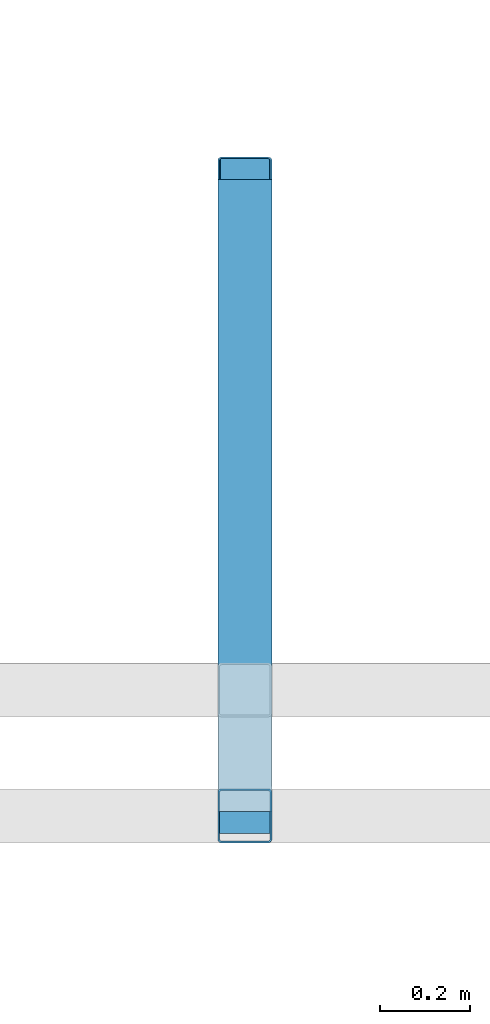
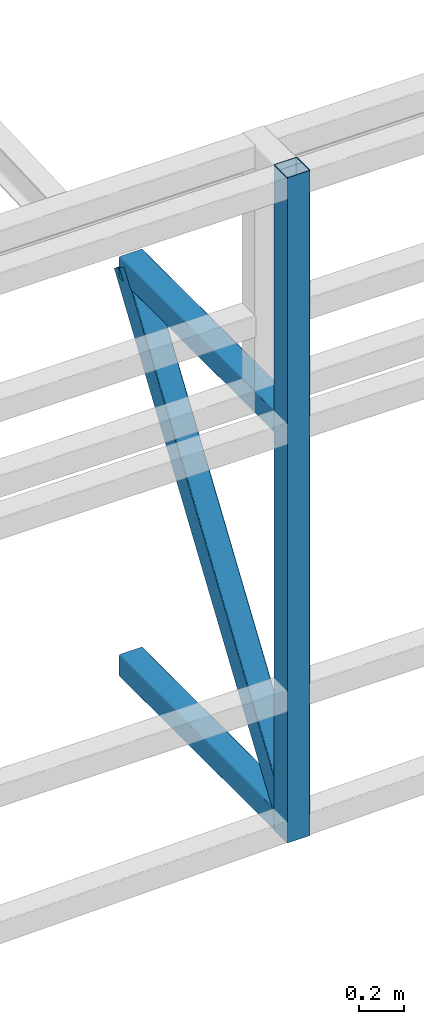
# One storey, part 115 of 215: 3 beams, 1 member, 4 elements without a shape of their own.
"""IFC2X3 building model written with IfcOpenShell, lengths in millimetres."""

from ifc_helpers import new_model, si_unit, frame, origin_with_axes, origin_2d_with_axis, place, context, subcontext, project, spatial, hollow_rectangle, extrude, material, type_object, element, aggregate, save


model = new_model("IFC2X3")

# Units and contexts
model_context = context("Model", 3, precision=1e-05, world=origin_with_axes())
body_context = subcontext(model_context, "Body", "Model", "MODEL_VIEW")
ifc_project = project(units=[si_unit("LENGTHUNIT", "METRE", prefix="MILLI"), si_unit("AREAUNIT", "SQUARE_METRE"), si_unit("VOLUMEUNIT", "CUBIC_METRE"), si_unit("MASSUNIT", "GRAM", prefix="KILO"), si_unit("TIMEUNIT", "SECOND"), si_unit("PLANEANGLEUNIT", "RADIAN"), si_unit("SOLIDANGLEUNIT", "STERADIAN"), si_unit("THERMODYNAMICTEMPERATUREUNIT", "DEGREE_CELSIUS"), si_unit("LUMINOUSINTENSITYUNIT", "LUMEN")], contexts=[model_context])

# Site, building, storey
site_placement = place(None, origin_with_axes())
site = spatial("IfcSite", under=ifc_project, at=site_placement, CompositionType="ELEMENT")
building_placement = place(site_placement, origin_with_axes())
building = spatial("IfcBuilding", under=site, at=building_placement, Name="Undefined", CompositionType="ELEMENT")
storey_placement = place(building_placement, origin_with_axes())
storey = spatial("IfcBuildingStorey", under=building, at=storey_placement, Name="Undefined", CompositionType="ELEMENT", Elevation=0.0)

# Assembly, beam
assembly_1_placement = place(storey_placement, origin_with_axes())
assembly_1 = element("IfcElementAssembly", 1, at=assembly_1_placement, inside=storey, Name="Steel Assembly", AssemblyPlace="NOTDEFINED", PredefinedType="RIGID_FRAME")
ifc_material = material(Name="STEEL/S275JR")
beam_type = type_object("IfcBeamType", PredefinedType="NOTDEFINED")
beam_1_placement = place(assembly_1_placement, frame((134605.010285256, 34554.9274900555, 827.155539383219), z_axis=(0.0, 0.0, 1.0), x_axis=(-6.93889390390723e-18, -1.0, -3.46944695195361e-18)))
beam_1 = element("IfcBeam", 2, at=beam_1_placement, type_object=beam_type, material=ifc_material, Name="LISSE", context=body_context, shape_type="SweptSolid", body=[
    extrude(hollow_rectangle(XDim=120.0, YDim=120.0, WallThickness=4.0, InnerFilletRadius=4.0, OuterFilletRadius=8.0, at=origin_2d_with_axis()), frame((1404.9181154153, 1.48751491493898e-19, -2.84217094304217e-14), z_axis=(-1.0, 0.0, 0.0), x_axis=(-6.93889390390723e-18, -1.0, -3.46944695195361e-18)), (0.0, 0.0, 1.0), 1404.9),
])
aggregate(assembly_1, [beam_1])

assembly_2_placement = place(storey_placement, origin_with_axes())
assembly_2 = element("IfcElementAssembly", 3, at=assembly_2_placement, inside=storey, Name="Steel Assembly", AssemblyPlace="NOTDEFINED", PredefinedType="RIGID_FRAME")
beam_2_placement = place(assembly_2_placement, frame((134605.011693152, 34554.9240843928, 2963.99602185051), z_axis=(0.0, 0.0, -1.0), x_axis=(-4.41999996209638e-07, -0.999999999999642, 7.22000000069896e-07)))
beam_2 = element("IfcBeam", 4, at=beam_2_placement, type_object=beam_type, material=ifc_material, Name="LISSE", context=body_context, shape_type="SweptSolid", body=[
    extrude(hollow_rectangle(XDim=120.0, YDim=120.0, WallThickness=4.0, InnerFilletRadius=4.0, OuterFilletRadius=8.0, at=origin_2d_with_axis()), frame((1404.89231313232, 5.39143026605448e-20, -1.48748759570922e-19), z_axis=(-1.0, 0.0, 0.0), x_axis=(-6.93889390390723e-18, -1.0, -3.46944695195361e-18)), (0.0, 0.0, 1.0), 1404.9),
])
aggregate(assembly_2, [beam_2])

assembly_3_placement = place(storey_placement, origin_with_axes())
assembly_3 = element("IfcElementAssembly", 5, at=assembly_3_placement, inside=storey, Name="Steel Assembly", AssemblyPlace="NOTDEFINED", PredefinedType="RIGID_FRAME")
beam_3_placement = place(assembly_3_placement, frame((134605.011410734, 33139.9549939152, 4339.19097174734), z_axis=(1.91399999311775e-06, -0.999999999998168, 0.0), x_axis=(0.0, 0.0, -1.0)))
beam_3 = element("IfcBeam", 6, at=beam_3_placement, type_object=beam_type, material=ifc_material, Name="LISSE", context=body_context, shape_type="SweptSolid", body=[
    extrude(hollow_rectangle(XDim=120.0, YDim=120.0, WallThickness=4.0, InnerFilletRadius=4.0, OuterFilletRadius=8.0, at=origin_2d_with_axis()), frame((3570.69100096889, 0.0, 0.0), z_axis=(-1.0, 0.0, 0.0), x_axis=(-6.93889390390723e-18, -1.0, -3.46944695195361e-18)), (0.0, 0.0, 1.0), 3570.7),
])
aggregate(assembly_3, [beam_3])

# Assembly, member
assembly_4_placement = place(storey_placement, origin_with_axes())
assembly_4 = element("IfcElementAssembly", 7, at=assembly_4_placement, inside=storey, Name="Steel Assembly", AssemblyPlace="NOTDEFINED", PredefinedType="RIGID_FRAME")
member_type = type_object("IfcMemberType", PredefinedType="NOTDEFINED")
member_placement = place(assembly_4_placement, frame((134605.014869548, 33150.0095363629, 887.155531883219), z_axis=(-0.00165792200077796, -0.828283564382141, 0.560306691258506), x_axis=(-1.26800000093105e-06, 0.560307463278539, 0.828284701411756)))
member = element("IfcMember", 8, at=member_placement, type_object=member_type, material=ifc_material, Name="LISSE", context=body_context, shape_type="SweptSolid", body=[
    extrude(hollow_rectangle(XDim=120.0, YDim=120.0, WallThickness=4.0, InnerFilletRadius=4.0, OuterFilletRadius=8.0, at=origin_2d_with_axis()), frame((2507.39931134504, 0.0, 0.0), z_axis=(-1.0, 0.0, 0.0), x_axis=(-6.93889390390723e-18, -1.0, -3.46944695195361e-18)), (0.0, 0.0, 1.0), 2507.4),
])
aggregate(assembly_4, [member])

save(model, "model.ifc")
